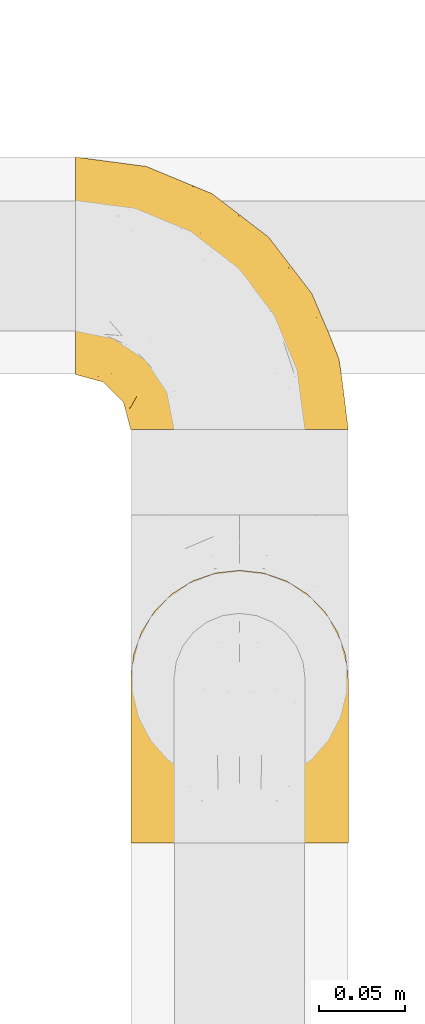
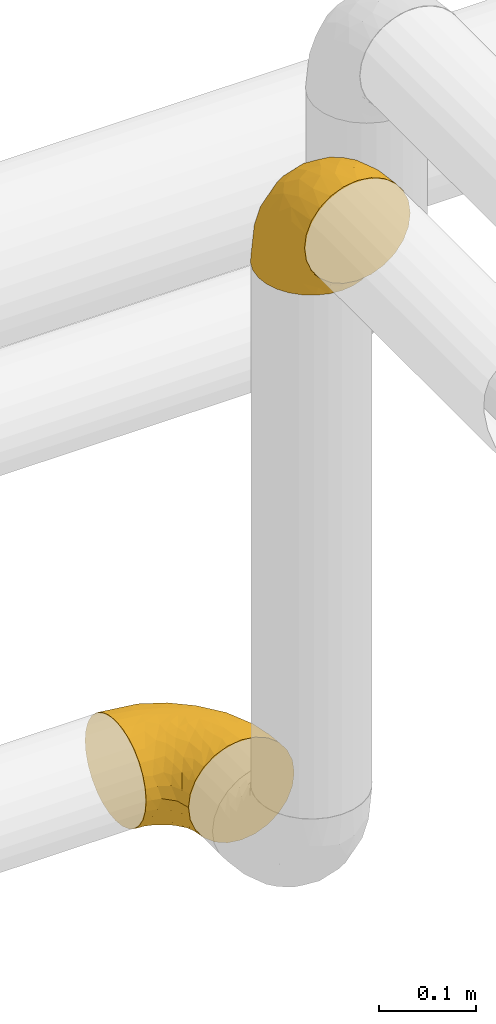
# One storey, part 120 of 827: 2 coverings.
"""IFC2X3 building model written with IfcOpenShell, lengths in millimetres."""

from ifc_helpers import new_model, entity, si_unit, converted_unit, derived_unit, direction, frame, origin, place, context, subcontext, project, spatial, faceted_brep, element, save


model = new_model("IFC2X3")

# Units and contexts
model_context = context("Model", 3, precision=0.01, world=origin(), true_north=direction((6.12303176911189e-17, 1.0)))
body_context = subcontext(model_context, "Body", "Model", "MODEL_VIEW")
ifc_project = project(units=[si_unit("LENGTHUNIT", "METRE", prefix="MILLI"), si_unit("AREAUNIT", "SQUARE_METRE"), si_unit("VOLUMEUNIT", "CUBIC_METRE"), converted_unit("PLANEANGLEUNIT", "DEGREE", entity("IfcRatioMeasure", 0.0174532925199433), si_unit("PLANEANGLEUNIT", "RADIAN"), dimensions=[0, 0, 0, 0, 0, 0, 0]), si_unit("MASSUNIT", "GRAM", prefix="KILO"), derived_unit("MASSDENSITYUNIT", [(si_unit("MASSUNIT", "GRAM", prefix="KILO"), 1), (si_unit("LENGTHUNIT", "METRE"), -3)]), derived_unit("MOMENTOFINERTIAUNIT", [(si_unit("LENGTHUNIT", "METRE"), 4)]), si_unit("TIMEUNIT", "SECOND"), si_unit("FREQUENCYUNIT", "HERTZ"), si_unit("THERMODYNAMICTEMPERATUREUNIT", "DEGREE_CELSIUS"), derived_unit("THERMALTRANSMITTANCEUNIT", [(si_unit("MASSUNIT", "GRAM", prefix="KILO"), 1), (si_unit("THERMODYNAMICTEMPERATUREUNIT", "KELVIN"), -1), (si_unit("TIMEUNIT", "SECOND"), -3)]), derived_unit("VOLUMETRICFLOWRATEUNIT", [(si_unit("LENGTHUNIT", "METRE"), 3), (si_unit("TIMEUNIT", "SECOND"), -1)]), derived_unit("MASSFLOWRATEUNIT", [(si_unit("MASSUNIT", "GRAM", prefix="KILO"), 1), (si_unit("TIMEUNIT", "SECOND"), -1)]), derived_unit("ROTATIONALFREQUENCYUNIT", [(si_unit("TIMEUNIT", "SECOND"), -1)]), si_unit("ELECTRICCURRENTUNIT", "AMPERE"), si_unit("ELECTRICVOLTAGEUNIT", "VOLT"), si_unit("POWERUNIT", "WATT"), si_unit("FORCEUNIT", "NEWTON", prefix="KILO"), si_unit("ILLUMINANCEUNIT", "LUX"), si_unit("LUMINOUSFLUXUNIT", "LUMEN"), si_unit("LUMINOUSINTENSITYUNIT", "CANDELA"), derived_unit("USERDEFINED", [(si_unit("MASSUNIT", "GRAM", prefix="KILO"), -1), (si_unit("LENGTHUNIT", "METRE"), -2), (si_unit("TIMEUNIT", "SECOND"), 3), (si_unit("LUMINOUSFLUXUNIT", "LUMEN"), 1)]), derived_unit("LINEARVELOCITYUNIT", [(si_unit("LENGTHUNIT", "METRE"), 1), (si_unit("TIMEUNIT", "SECOND"), -1)]), si_unit("PRESSUREUNIT", "PASCAL"), derived_unit("USERDEFINED", [(si_unit("LENGTHUNIT", "METRE"), -2), (si_unit("MASSUNIT", "GRAM", prefix="KILO"), 1), (si_unit("TIMEUNIT", "SECOND"), -2)]), derived_unit("LINEARFORCEUNIT", [(si_unit("MASSUNIT", "GRAM", prefix="KILO"), 1), (si_unit("LENGTHUNIT", "METRE"), 1), (si_unit("TIMEUNIT", "SECOND"), -2), (si_unit("LENGTHUNIT", "METRE"), -1)]), derived_unit("PLANARFORCEUNIT", [(si_unit("MASSUNIT", "GRAM", prefix="KILO"), 1), (si_unit("LENGTHUNIT", "METRE"), 1), (si_unit("TIMEUNIT", "SECOND"), -2), (si_unit("LENGTHUNIT", "METRE"), -2)])], contexts=[model_context])

# Site, building, storey
site_placement = place(None, origin())
site = spatial("IfcSite", under=ifc_project, at=site_placement, CompositionType="ELEMENT")
building_placement = place(site_placement, origin())
building = spatial("IfcBuilding", under=site, at=building_placement, CompositionType="ELEMENT")
storey_placement = place(building_placement, frame((0.0, 0.0, 28200.0)))
storey = spatial("IfcBuildingStorey", under=building, at=storey_placement, Name="08", CompositionType="ELEMENT", Elevation=28200.0)

# Coverings
covering_1_placement = place(storey_placement, frame((26598.99, 11733.86, 3353.4)))
element("IfcCovering", 1, at=covering_1_placement, inside=storey, Name=":ADSK_", ObjectType=":ADSK_", PredefinedType="INSULATION", context=body_context, shape_type="Brep", body=[
    faceted_brep([(3.18, 110.62, 1.6), (7.84, 123.95, 1.6), (15.35, 135.9, 1.6), (25.33, 145.89, 1.6), (37.29, 153.4, 1.6), (50.61, 158.06, 1.6), (64.65, 159.65, 1.6), (78.67, 158.06, 1.6), (92.0, 153.4, 1.6), (103.95, 145.89, 1.6), (113.94, 135.91, 1.6), (121.45, 123.95, 1.6), (126.11, 110.63, 1.6), (127.7, 96.6, 1.6), (126.11, 82.57, 1.6), (121.45, 69.24, 1.6), (113.94, 57.29, 1.6), (103.96, 47.3, 1.6), (92.0, 39.79, 1.6), (78.68, 35.13, 1.6), (64.65, 33.55, 1.6), (50.62, 35.13, 1.6), (37.29, 39.79, 1.6), (25.34, 47.3, 1.6), (15.35, 57.28, 1.6), (7.84, 69.24, 1.6), (3.18, 82.56, 1.6), (1.6, 96.6, 1.6), (64.65, 1.6, 33.55), (80.96, 1.6, 35.69), (96.17, 1.6, 41.99), (109.23, 1.6, 52.01), (119.25, 1.6, 65.07), (125.55, 1.6, 80.28), (126.29, 1.6, 85.89), (127.7, 1.6, 96.6), (125.55, 1.6, 112.91), (119.25, 1.6, 128.12), (109.23, 1.6, 141.18), (96.17, 1.6, 151.2), (80.96, 1.6, 157.5), (64.65, 1.6, 159.65), (48.33, 1.6, 157.5), (33.12, 1.6, 151.2), (20.06, 1.6, 141.18), (10.04, 1.6, 128.12), (3.74, 1.6, 112.91), (1.6, 1.6, 96.6), (3.01, 1.6, 85.89), (3.74, 1.6, 80.28), (10.04, 1.6, 65.07), (20.06, 1.6, 52.01), (33.12, 1.6, 41.99), (48.33, 1.6, 35.69), (28.19, 30.13, 145.23), (42.57, 39.4, 150.95), (30.59, 62.65, 136.48), (53.36, 28.52, 156.3), (64.65, 42.5, 154.26), (15.9, 115.57, 73.92), (18.23, 98.94, 98.94), (32.42, 111.29, 102.72), (45.22, 95.5, 124.89), (64.65, 80.62, 138.47), (64.65, 113.35, 113.35), (9.73, 43.71, 120.33), (16.54, 70.76, 118.42), (6.44, 62.71, 103.99), (4.21, 33.16, 110.05), (2.65, 53.41, 94.6), (23.51, 130.65, 62.68), (35.48, 137.68, 66.8), (33.22, 146.84, 37.71), (42.18, 66.58, 141.12), (53.52, 57.7, 148.29), (17.3, 39.88, 132.76), (64.65, 154.26, 42.5), (45.71, 152.07, 39.36), (48.33, 125.54, 96.16), (50.95, 142.81, 69.16), (6.44, 103.99, 62.71), (3.41, 79.4, 79.4), (8.33, 88.81, 88.81), (2.62, 104.86, 26.93), (6.65, 117.38, 32.13), (1.6, 57.43, 78.45), (1.6, 44.19, 85.2), (1.6, 30.95, 91.95), (22.17, 139.96, 31.66), (14.22, 127.03, 45.38), (26.48, 87.17, 118.88), (1.6, 78.45, 57.43), (1.6, 73.2, 62.69), (1.6, 67.94, 67.94), (1.6, 94.63, 13.99), (1.6, 93.29, 22.47), (1.6, 91.95, 30.95), (2.65, 94.6, 53.41), (1.6, 85.2, 44.19), (64.65, 138.47, 80.62), (1.6, 13.99, 94.63), (16.24, 40.46, 39.95), (27.48, 32.36, 33.15), (20.83, 28.71, 43.2), (3.08, 15.53, 81.77), (6.64, 29.06, 66.3), (2.74, 40.03, 75.23), (3.84, 45.36, 66.55), (3.28, 26.46, 78.18), (5.99, 47.56, 56.85), (10.3, 36.28, 54.23), (15.78, 55.57, 12.94), (24.69, 45.02, 17.42), (11.25, 57.55, 27.05), (27.69, 11.56, 44.37), (19.31, 19.2, 49.66), (37.19, 10.07, 38.88), (33.01, 21.04, 37.08), (8.24, 15.52, 66.96), (49.89, 13.84, 32.99), (50.1, 32.67, 14.52), (48.9, 24.86, 26.32), (36.15, 34.31, 22.37), (2.54, 81.47, 27.96), (3.58, 71.26, 39.47), (3.12, 81.64, 15.41), (64.65, 29.26, 17.57), (6.01, 70.65, 21.32), (64.65, 31.93, 7.61), (37.71, 27.99, 28.92), (22.19, 41.71, 28.65), (13.01, 50.14, 34.82), (12.97, 17.57, 58.27), (38.95, 37.62, 11.73), (6.55, 60.48, 40.36), (64.65, 17.57, 29.26), (2.52, 56.96, 65.12), (9.45, 48.98, 45.4), (4.58, 57.29, 53.05), (2.83, 68.25, 50.39), (92.1, 10.07, 38.88), (101.63, 16.58, 42.9), (79.39, 13.84, 32.99), (127.7, 13.99, 94.63), (79.2, 32.67, 14.52), (80.4, 24.86, 26.32), (126.41, 67.81, 50.51), (122.74, 61.09, 39.41), (125.71, 71.26, 39.47), (127.7, 57.43, 78.45), (127.7, 44.19, 85.2), (126.55, 40.03, 75.23), (118.04, 57.55, 27.05), (117.36, 51.01, 36.34), (108.2, 42.79, 28.89), (126.01, 26.46, 78.18), (122.65, 29.06, 66.3), (116.32, 17.57, 58.27), (109.98, 19.2, 49.66), (113.06, 40.46, 39.95), (107.85, 28.84, 42.42), (102.33, 33.48, 32.56), (121.05, 15.52, 66.96), (126.21, 15.53, 81.77), (118.99, 36.28, 54.23), (90.34, 37.62, 11.73), (96.28, 21.04, 37.08), (127.7, 94.63, 13.99), (127.7, 93.29, 22.47), (93.14, 34.31, 22.37), (104.6, 45.03, 17.42), (123.28, 70.65, 21.32), (126.75, 81.47, 27.96), (113.51, 55.58, 12.94), (127.7, 91.95, 30.95), (126.17, 81.64, 15.41), (91.96, 27.86, 29.3), (127.7, 78.45, 57.43), (127.7, 85.2, 44.19), (126.77, 56.96, 65.12), (125.45, 45.36, 66.55), (123.3, 47.57, 56.85), (119.94, 48.27, 46.41), (127.7, 67.94, 67.94), (124.71, 57.3, 53.04), (127.7, 30.95, 91.95), (98.7, 62.65, 136.48), (101.1, 30.13, 145.23), (111.99, 39.88, 132.76), (119.56, 43.71, 120.33), (86.72, 39.4, 150.95), (75.78, 55.79, 149.01), (75.87, 28.41, 156.33), (126.64, 53.41, 94.6), (126.67, 104.86, 26.93), (122.63, 117.39, 32.14), (122.85, 103.99, 62.71), (80.96, 125.54, 96.16), (96.87, 111.29, 102.72), (93.81, 137.69, 66.79), (126.64, 94.6, 53.41), (125.88, 79.4, 79.4), (125.08, 33.16, 110.05), (86.22, 68.78, 140.44), (105.77, 130.66, 62.68), (107.12, 139.97, 31.66), (96.19, 148.6, 29.31), (113.39, 115.58, 73.92), (115.06, 127.03, 45.39), (112.75, 70.76, 118.42), (84.07, 95.5, 124.89), (122.85, 62.71, 103.99), (120.97, 88.81, 88.81), (111.06, 98.94, 98.94), (96.3, 89.09, 122.85), (75.94, 78.72, 138.38), (80.53, 142.21, 69.18), (83.57, 152.07, 39.36)], [[[0, 1, 2, 3, 4, 5, 6, 7, 8, 9, 10, 11, 12, 13, 14, 15, 16, 17, 18, 19, 20, 21, 22, 23, 24, 25, 26, 27]], [[28, 29, 30, 31, 32, 33, 34, 35, 36, 37, 38, 39, 40, 41, 42, 43, 44, 45, 46, 47, 48, 49, 50, 51, 52, 53]], [[54, 55, 56]], [[57, 41, 58]], [[59, 60, 61]], [[62, 63, 64]], [[65, 66, 67]], [[68, 67, 69]], [[70, 71, 72]], [[55, 73, 56]], [[43, 42, 55]], [[55, 74, 73]], [[44, 75, 45]], [[44, 43, 54]], [[76, 5, 77]], [[71, 78, 79]], [[45, 75, 65]], [[46, 68, 47]], [[80, 81, 82]], [[0, 83, 84]], [[69, 85, 86, 87]], [[69, 81, 85]], [[84, 1, 0]], [[2, 88, 3]], [[4, 3, 72]], [[44, 54, 75]], [[5, 4, 77]], [[89, 2, 1]], [[72, 3, 88]], [[5, 76, 6]], [[70, 88, 89]], [[68, 65, 67]], [[88, 2, 89]], [[56, 90, 66]], [[64, 78, 62]], [[81, 91, 92, 93, 85]], [[83, 27, 94, 95, 96]], [[62, 61, 90]], [[97, 96, 98, 91]], [[80, 97, 81]], [[42, 57, 55]], [[62, 78, 61]], [[84, 89, 1]], [[78, 64, 99]], [[57, 74, 55]], [[76, 77, 79]], [[77, 72, 71]], [[82, 81, 67]], [[97, 83, 96]], [[80, 89, 84]], [[79, 78, 99]], [[71, 70, 61]], [[81, 97, 91]], [[83, 80, 84]], [[68, 87, 100, 47]], [[81, 69, 67]], [[68, 69, 87]], [[65, 46, 45]], [[65, 68, 46]], [[66, 65, 75]], [[56, 66, 75]], [[66, 60, 82]], [[71, 61, 78]], [[60, 66, 90]], [[83, 97, 80]], [[27, 83, 0]], [[59, 70, 89]], [[70, 59, 61]], [[89, 80, 59]], [[82, 59, 80]], [[55, 54, 43]], [[75, 54, 56]], [[66, 82, 67]], [[59, 82, 60]], [[41, 57, 42]], [[74, 57, 58]], [[58, 63, 74]], [[62, 74, 63]], [[74, 62, 73]], [[62, 56, 73]], [[4, 72, 77]], [[70, 72, 88]], [[76, 79, 99]], [[71, 79, 77]], [[62, 90, 56]], [[60, 90, 61]], [[101, 102, 103]], [[100, 87, 104]], [[105, 106, 107]], [[108, 104, 87]], [[107, 109, 110]], [[108, 87, 86]], [[111, 112, 113]], [[114, 51, 115]], [[116, 114, 117]], [[51, 50, 118]], [[119, 28, 53]], [[120, 121, 122]], [[98, 123, 124]], [[125, 96, 95]], [[116, 53, 52]], [[126, 121, 120]], [[104, 108, 118]], [[98, 124, 91]], [[25, 24, 127]], [[120, 128, 126]], [[122, 129, 102]], [[95, 94, 27, 26]], [[122, 102, 130]], [[125, 127, 123]], [[24, 111, 127]], [[21, 20, 128]], [[112, 130, 131]], [[48, 47, 100, 49]], [[132, 110, 115]], [[23, 111, 24]], [[129, 119, 117]], [[120, 133, 21]], [[112, 23, 22]], [[134, 113, 131]], [[121, 126, 135]], [[133, 112, 22]], [[128, 120, 21]], [[132, 51, 118]], [[120, 122, 133]], [[119, 121, 135]], [[129, 117, 102]], [[125, 26, 25]], [[26, 125, 95]], [[127, 125, 25]], [[28, 119, 135]], [[119, 53, 116]], [[127, 113, 124]], [[96, 125, 123]], [[112, 131, 113]], [[101, 103, 110]], [[85, 93, 136]], [[124, 123, 127]], [[98, 96, 123]], [[112, 111, 23]], [[127, 111, 113]], [[112, 133, 122]], [[21, 133, 22]], [[107, 110, 105]], [[110, 109, 137]], [[86, 106, 108]], [[138, 109, 136]], [[105, 118, 108]], [[107, 106, 85]], [[104, 50, 49]], [[124, 134, 139]], [[138, 93, 92]], [[92, 91, 139]], [[100, 104, 49]], [[118, 105, 132]], [[104, 118, 50]], [[110, 132, 105]], [[51, 132, 115]], [[108, 106, 105]], [[85, 106, 86]], [[114, 116, 52]], [[119, 116, 117]], [[51, 114, 52]], [[114, 115, 103]], [[117, 114, 103]], [[130, 102, 101]], [[117, 103, 102]], [[110, 103, 115]], [[130, 101, 131]], [[122, 130, 112]], [[101, 137, 131]], [[113, 134, 124]], [[137, 134, 131]], [[124, 139, 91]], [[134, 138, 139]], [[92, 139, 138]], [[110, 137, 101]], [[134, 137, 138]], [[136, 109, 107]], [[137, 109, 138]], [[85, 136, 107]], [[138, 136, 93]], [[122, 121, 129]], [[129, 121, 119]], [[30, 140, 141]], [[30, 29, 140]], [[28, 135, 142]], [[143, 35, 34, 33]], [[19, 144, 128]], [[126, 145, 135]], [[146, 147, 148]], [[149, 150, 151]], [[152, 153, 154]], [[155, 156, 151]], [[157, 31, 158]], [[159, 160, 161]], [[32, 162, 163]], [[158, 31, 30]], [[157, 164, 156]], [[126, 144, 145]], [[126, 128, 144]], [[18, 165, 19]], [[141, 166, 160]], [[14, 13, 167, 168]], [[163, 143, 33]], [[169, 165, 170]], [[18, 17, 170]], [[153, 159, 154]], [[142, 135, 145]], [[148, 171, 172]], [[159, 161, 154]], [[171, 152, 173]], [[173, 17, 16]], [[16, 15, 171]], [[158, 160, 164]], [[174, 175, 168]], [[173, 170, 17]], [[19, 128, 20]], [[174, 172, 175]], [[165, 169, 144]], [[162, 157, 156]], [[175, 172, 171]], [[144, 169, 145]], [[176, 169, 161]], [[166, 140, 142]], [[175, 171, 15]], [[168, 175, 14]], [[14, 175, 15]], [[142, 145, 176]], [[28, 142, 29]], [[148, 177, 146]], [[148, 178, 177]], [[152, 171, 148]], [[179, 180, 181]], [[164, 180, 156]], [[174, 178, 172]], [[148, 172, 178]], [[171, 173, 16]], [[170, 173, 152]], [[19, 165, 144]], [[170, 165, 18]], [[153, 182, 159]], [[146, 183, 184]], [[181, 180, 164]], [[180, 151, 156]], [[163, 155, 185]], [[155, 150, 185]], [[162, 156, 155]], [[143, 163, 185]], [[180, 179, 149]], [[32, 163, 33]], [[163, 162, 155]], [[31, 162, 32]], [[31, 157, 162]], [[164, 157, 158]], [[149, 151, 180]], [[155, 151, 150]], [[142, 140, 29]], [[141, 140, 166]], [[176, 145, 169]], [[30, 141, 158]], [[164, 160, 159]], [[158, 141, 160]], [[166, 161, 160]], [[154, 169, 170]], [[169, 154, 161]], [[152, 154, 170]], [[147, 152, 148]], [[153, 147, 182]], [[181, 182, 184]], [[164, 159, 182]], [[161, 166, 176]], [[142, 176, 166]], [[183, 146, 177]], [[184, 182, 147]], [[184, 147, 146]], [[152, 147, 153]], [[182, 181, 164]], [[179, 184, 183]], [[184, 179, 181]], [[149, 179, 183]], [[186, 187, 188]], [[37, 36, 189]], [[190, 191, 192]], [[193, 185, 150, 149]], [[194, 195, 196]], [[197, 198, 199]], [[200, 201, 177]], [[193, 202, 185]], [[203, 190, 186]], [[202, 189, 36]], [[41, 40, 192]], [[204, 205, 199]], [[9, 8, 206]], [[187, 190, 39]], [[40, 39, 190]], [[38, 37, 188]], [[207, 208, 204]], [[202, 35, 143, 185]], [[39, 38, 187]], [[195, 11, 208]], [[201, 149, 183, 177]], [[188, 189, 209]], [[197, 64, 210]], [[186, 188, 209]], [[13, 12, 194]], [[211, 201, 212]], [[12, 11, 195]], [[193, 201, 211]], [[212, 201, 196]], [[10, 208, 11]], [[213, 214, 209]], [[64, 63, 215]], [[216, 197, 199]], [[8, 217, 206]], [[7, 217, 8]], [[203, 191, 190]], [[7, 6, 76]], [[208, 205, 204]], [[205, 10, 9]], [[199, 205, 206]], [[7, 76, 217]], [[205, 208, 10]], [[216, 76, 99]], [[200, 177, 178, 174]], [[64, 197, 99]], [[63, 58, 191]], [[208, 196, 195]], [[196, 200, 194]], [[198, 197, 210]], [[216, 199, 217]], [[201, 193, 149]], [[202, 193, 211]], [[202, 211, 189]], [[35, 202, 36]], [[211, 212, 209]], [[37, 189, 188]], [[211, 209, 189]], [[213, 198, 214]], [[200, 174, 194]], [[201, 200, 196]], [[214, 198, 210]], [[213, 207, 198]], [[194, 174, 168, 167, 13]], [[195, 194, 12]], [[198, 204, 199]], [[204, 198, 207]], [[212, 207, 213]], [[196, 208, 207]], [[188, 187, 38]], [[190, 187, 186]], [[207, 212, 196]], [[209, 212, 213]], [[214, 203, 186]], [[191, 215, 63]], [[191, 203, 215]], [[192, 191, 58]], [[41, 192, 58]], [[190, 192, 40]], [[203, 210, 215]], [[64, 215, 210]], [[199, 206, 217]], [[9, 206, 205]], [[76, 216, 217]], [[99, 197, 216]], [[203, 214, 210]], [[209, 214, 186]]]),
])
covering_2_placement = place(storey_placement, frame((26567.04, 11973.41, 2535.35)))
element("IfcCovering", 2, at=covering_2_placement, inside=storey, Name=":ADSK_", ObjectType=":ADSK_", PredefinedType="INSULATION", context=body_context, shape_type="Brep", body=[
    faceted_brep([(1.6, 110.62, 126.11), (1.6, 123.95, 121.45), (1.6, 135.9, 113.94), (1.6, 145.89, 103.96), (1.6, 153.4, 92.0), (1.6, 158.06, 78.68), (1.6, 159.65, 64.65), (1.6, 158.06, 50.62), (1.6, 153.4, 37.29), (1.6, 145.89, 25.34), (1.6, 135.91, 15.35), (1.6, 123.95, 7.84), (1.6, 110.63, 3.18), (1.6, 96.6, 1.6), (1.6, 82.57, 3.18), (1.6, 69.24, 7.84), (1.6, 57.29, 15.35), (1.6, 47.3, 25.33), (1.6, 39.79, 37.29), (1.6, 35.13, 50.61), (1.6, 33.55, 64.65), (1.6, 35.13, 78.67), (1.6, 39.79, 92.0), (1.6, 47.3, 103.95), (1.6, 57.28, 113.94), (1.6, 69.24, 121.45), (1.6, 82.56, 126.11), (1.6, 96.6, 127.7), (33.55, 1.6, 64.65), (35.69, 1.6, 48.33), (41.99, 1.6, 33.12), (52.01, 1.6, 20.06), (65.07, 1.6, 10.04), (80.28, 1.6, 3.74), (85.89, 1.6, 3.01), (96.6, 1.6, 1.6), (112.91, 1.6, 3.74), (128.12, 1.6, 10.04), (141.18, 1.6, 20.06), (151.2, 1.6, 33.12), (157.5, 1.6, 48.33), (159.65, 1.6, 64.65), (157.5, 1.6, 80.96), (151.2, 1.6, 96.17), (141.18, 1.6, 109.23), (128.12, 1.6, 119.25), (112.91, 1.6, 125.55), (96.6, 1.6, 127.7), (85.89, 1.6, 126.29), (80.28, 1.6, 125.55), (65.07, 1.6, 119.25), (52.01, 1.6, 109.23), (41.99, 1.6, 96.17), (35.69, 1.6, 80.96), (145.23, 30.13, 101.1), (150.95, 39.4, 86.72), (136.48, 62.65, 98.7), (156.3, 28.52, 75.93), (154.26, 42.5, 64.65), (73.92, 115.57, 113.39), (98.94, 98.94, 111.06), (102.72, 111.29, 96.87), (124.89, 95.5, 84.07), (138.47, 80.62, 64.65), (113.35, 113.35, 64.65), (120.33, 43.71, 119.56), (118.42, 70.76, 112.75), (103.99, 62.71, 122.85), (110.05, 33.16, 125.08), (94.6, 53.41, 126.64), (62.68, 130.65, 105.78), (66.8, 137.68, 93.81), (37.71, 146.84, 96.07), (141.12, 66.58, 87.11), (148.29, 57.7, 75.77), (132.76, 39.88, 111.99), (42.5, 154.26, 64.65), (39.36, 152.07, 83.58), (96.16, 125.54, 80.96), (69.16, 142.81, 78.34), (62.71, 103.99, 122.85), (79.4, 79.4, 125.88), (88.81, 88.81, 120.97), (26.93, 104.86, 126.67), (32.13, 117.38, 122.64), (78.45, 57.43, 127.7), (85.2, 44.19, 127.7), (91.95, 30.95, 127.7), (31.66, 139.96, 107.12), (45.38, 127.03, 115.07), (118.88, 87.17, 102.81), (57.43, 78.45, 127.7), (62.69, 73.2, 127.7), (67.94, 67.94, 127.7), (13.99, 94.63, 127.7), (22.47, 93.29, 127.7), (30.95, 91.95, 127.7), (53.41, 94.6, 126.64), (44.19, 85.2, 127.7), (80.62, 138.47, 64.65), (94.63, 13.99, 127.7), (39.95, 40.46, 113.05), (33.15, 32.36, 101.81), (43.2, 28.71, 108.46), (81.77, 15.53, 126.21), (66.3, 29.06, 122.65), (75.23, 40.03, 126.55), (66.55, 45.36, 125.45), (78.18, 26.46, 126.01), (56.85, 47.56, 123.3), (54.23, 36.28, 118.99), (12.94, 55.57, 113.51), (17.42, 45.02, 104.6), (27.05, 57.55, 118.04), (44.37, 11.56, 101.6), (49.66, 19.2, 109.98), (38.88, 10.07, 92.1), (37.08, 21.04, 96.28), (66.96, 15.52, 121.05), (32.99, 13.84, 79.4), (14.52, 32.67, 79.19), (26.32, 24.86, 80.39), (22.37, 34.31, 93.14), (27.96, 81.47, 126.75), (39.47, 71.26, 125.71), (15.41, 81.64, 126.17), (17.57, 29.26, 64.65), (21.32, 70.65, 123.28), (7.61, 31.93, 64.65), (28.92, 27.99, 91.58), (28.65, 41.71, 107.1), (34.82, 50.14, 116.28), (58.27, 17.57, 116.32), (11.73, 37.62, 90.34), (40.36, 60.48, 122.74), (29.26, 17.57, 64.65), (65.12, 56.96, 126.77), (45.4, 48.98, 119.84), (53.05, 57.29, 124.71), (50.39, 68.25, 126.47), (38.88, 10.07, 37.19), (42.9, 16.58, 27.66), (32.99, 13.84, 49.9), (94.63, 13.99, 1.6), (14.52, 32.67, 50.1), (26.32, 24.86, 48.89), (50.51, 67.81, 2.88), (39.41, 61.09, 6.55), (39.47, 71.26, 3.58), (78.45, 57.43, 1.6), (85.2, 44.19, 1.6), (75.23, 40.03, 2.74), (27.05, 57.55, 11.25), (36.34, 51.01, 11.93), (28.89, 42.79, 21.09), (78.18, 26.46, 3.28), (66.3, 29.06, 6.64), (58.27, 17.57, 12.97), (49.66, 19.2, 19.31), (39.95, 40.46, 16.23), (42.42, 28.84, 21.44), (32.56, 33.48, 26.96), (66.96, 15.52, 8.24), (81.77, 15.53, 3.08), (54.23, 36.28, 10.3), (11.73, 37.62, 38.95), (37.08, 21.04, 33.01), (13.99, 94.63, 1.6), (22.47, 93.29, 1.6), (22.37, 34.31, 36.15), (17.42, 45.03, 24.69), (21.32, 70.65, 6.01), (27.96, 81.47, 2.54), (12.94, 55.58, 15.78), (30.95, 91.95, 1.6), (15.41, 81.64, 3.12), (29.3, 27.86, 37.33), (57.43, 78.45, 1.6), (44.19, 85.2, 1.6), (65.12, 56.96, 2.52), (66.55, 45.36, 3.84), (56.85, 47.57, 5.99), (46.41, 48.27, 9.35), (67.94, 67.94, 1.6), (53.04, 57.3, 4.58), (91.95, 30.95, 1.6), (136.48, 62.65, 30.59), (145.23, 30.13, 28.19), (132.76, 39.88, 17.3), (120.33, 43.71, 9.73), (150.95, 39.4, 42.57), (149.01, 55.79, 53.51), (156.33, 28.41, 53.42), (94.6, 53.41, 2.65), (26.93, 104.86, 2.62), (32.14, 117.39, 6.66), (62.71, 103.99, 6.44), (96.16, 125.54, 48.33), (102.72, 111.29, 32.42), (66.79, 137.69, 35.49), (53.41, 94.6, 2.65), (79.4, 79.4, 3.41), (110.05, 33.16, 4.21), (140.44, 68.78, 43.07), (62.68, 130.66, 23.52), (31.66, 139.97, 22.18), (29.31, 148.6, 33.1), (73.92, 115.58, 15.9), (45.39, 127.03, 14.23), (118.42, 70.76, 16.54), (124.89, 95.5, 45.22), (103.99, 62.71, 6.44), (88.81, 88.81, 8.33), (98.94, 98.94, 18.23), (122.85, 89.09, 32.99), (138.38, 78.72, 53.35), (69.18, 142.21, 48.76), (39.36, 152.07, 45.72)], [[[0, 1, 2, 3, 4, 5, 6, 7, 8, 9, 10, 11, 12, 13, 14, 15, 16, 17, 18, 19, 20, 21, 22, 23, 24, 25, 26, 27]], [[28, 29, 30, 31, 32, 33, 34, 35, 36, 37, 38, 39, 40, 41, 42, 43, 44, 45, 46, 47, 48, 49, 50, 51, 52, 53]], [[54, 55, 56]], [[57, 41, 58]], [[59, 60, 61]], [[62, 63, 64]], [[65, 66, 67]], [[68, 67, 69]], [[70, 71, 72]], [[55, 73, 56]], [[43, 42, 55]], [[55, 74, 73]], [[44, 75, 45]], [[44, 43, 54]], [[76, 5, 77]], [[71, 78, 79]], [[45, 75, 65]], [[46, 68, 47]], [[80, 81, 82]], [[0, 83, 84]], [[69, 85, 86, 87]], [[69, 81, 85]], [[84, 1, 0]], [[2, 88, 3]], [[4, 3, 72]], [[44, 54, 75]], [[5, 4, 77]], [[89, 2, 1]], [[72, 3, 88]], [[5, 76, 6]], [[70, 88, 89]], [[68, 65, 67]], [[88, 2, 89]], [[56, 90, 66]], [[64, 78, 62]], [[81, 91, 92, 93, 85]], [[83, 27, 94, 95, 96]], [[62, 61, 90]], [[97, 96, 98, 91]], [[80, 97, 81]], [[42, 57, 55]], [[62, 78, 61]], [[84, 89, 1]], [[78, 64, 99]], [[57, 74, 55]], [[76, 77, 79]], [[77, 72, 71]], [[82, 81, 67]], [[97, 83, 96]], [[80, 89, 84]], [[79, 78, 99]], [[71, 70, 61]], [[81, 97, 91]], [[83, 80, 84]], [[68, 87, 100, 47]], [[81, 69, 67]], [[68, 69, 87]], [[65, 46, 45]], [[65, 68, 46]], [[66, 65, 75]], [[56, 66, 75]], [[66, 60, 82]], [[71, 61, 78]], [[60, 66, 90]], [[83, 97, 80]], [[27, 83, 0]], [[59, 70, 89]], [[70, 59, 61]], [[89, 80, 59]], [[82, 59, 80]], [[55, 54, 43]], [[75, 54, 56]], [[66, 82, 67]], [[59, 82, 60]], [[41, 57, 42]], [[74, 57, 58]], [[58, 63, 74]], [[62, 74, 63]], [[74, 62, 73]], [[62, 56, 73]], [[4, 72, 77]], [[70, 72, 88]], [[76, 79, 99]], [[71, 79, 77]], [[62, 90, 56]], [[60, 90, 61]], [[101, 102, 103]], [[100, 87, 104]], [[105, 106, 107]], [[108, 104, 87]], [[107, 109, 110]], [[108, 87, 86]], [[111, 112, 113]], [[114, 51, 115]], [[116, 114, 117]], [[51, 50, 118]], [[119, 28, 53]], [[120, 121, 122]], [[98, 123, 124]], [[125, 96, 95]], [[116, 53, 52]], [[126, 121, 120]], [[104, 108, 118]], [[98, 124, 91]], [[25, 24, 127]], [[120, 128, 126]], [[122, 129, 102]], [[95, 94, 27, 26]], [[122, 102, 130]], [[125, 127, 123]], [[24, 111, 127]], [[21, 20, 128]], [[112, 130, 131]], [[48, 47, 100, 49]], [[132, 110, 115]], [[23, 111, 24]], [[129, 119, 117]], [[120, 133, 21]], [[112, 23, 22]], [[134, 113, 131]], [[121, 126, 135]], [[133, 112, 22]], [[128, 120, 21]], [[132, 51, 118]], [[120, 122, 133]], [[119, 121, 135]], [[129, 117, 102]], [[125, 26, 25]], [[26, 125, 95]], [[127, 125, 25]], [[28, 119, 135]], [[119, 53, 116]], [[127, 113, 124]], [[96, 125, 123]], [[112, 131, 113]], [[101, 103, 110]], [[85, 93, 136]], [[124, 123, 127]], [[98, 96, 123]], [[112, 111, 23]], [[127, 111, 113]], [[112, 133, 122]], [[21, 133, 22]], [[107, 110, 105]], [[110, 109, 137]], [[86, 106, 108]], [[138, 109, 136]], [[105, 118, 108]], [[107, 106, 85]], [[104, 50, 49]], [[124, 134, 139]], [[138, 93, 92]], [[92, 91, 139]], [[100, 104, 49]], [[118, 105, 132]], [[104, 118, 50]], [[110, 132, 105]], [[51, 132, 115]], [[108, 106, 105]], [[85, 106, 86]], [[114, 116, 52]], [[119, 116, 117]], [[51, 114, 52]], [[114, 115, 103]], [[117, 114, 103]], [[130, 102, 101]], [[117, 103, 102]], [[110, 103, 115]], [[130, 101, 131]], [[122, 130, 112]], [[101, 137, 131]], [[113, 134, 124]], [[137, 134, 131]], [[124, 139, 91]], [[134, 138, 139]], [[92, 139, 138]], [[110, 137, 101]], [[134, 137, 138]], [[136, 109, 107]], [[137, 109, 138]], [[85, 136, 107]], [[138, 136, 93]], [[122, 121, 129]], [[129, 121, 119]], [[30, 140, 141]], [[30, 29, 140]], [[28, 135, 142]], [[143, 35, 34, 33]], [[19, 144, 128]], [[126, 145, 135]], [[146, 147, 148]], [[149, 150, 151]], [[152, 153, 154]], [[155, 156, 151]], [[157, 31, 158]], [[159, 160, 161]], [[32, 162, 163]], [[158, 31, 30]], [[157, 164, 156]], [[126, 144, 145]], [[126, 128, 144]], [[18, 165, 19]], [[141, 166, 160]], [[14, 13, 167, 168]], [[163, 143, 33]], [[169, 165, 170]], [[18, 17, 170]], [[153, 159, 154]], [[142, 135, 145]], [[148, 171, 172]], [[159, 161, 154]], [[171, 152, 173]], [[173, 17, 16]], [[16, 15, 171]], [[158, 160, 164]], [[174, 175, 168]], [[173, 170, 17]], [[19, 128, 20]], [[174, 172, 175]], [[165, 169, 144]], [[162, 157, 156]], [[175, 172, 171]], [[144, 169, 145]], [[176, 169, 161]], [[166, 140, 142]], [[175, 171, 15]], [[168, 175, 14]], [[14, 175, 15]], [[142, 145, 176]], [[28, 142, 29]], [[148, 177, 146]], [[148, 178, 177]], [[152, 171, 148]], [[179, 180, 181]], [[164, 180, 156]], [[174, 178, 172]], [[148, 172, 178]], [[171, 173, 16]], [[170, 173, 152]], [[19, 165, 144]], [[170, 165, 18]], [[153, 182, 159]], [[146, 183, 184]], [[181, 180, 164]], [[180, 151, 156]], [[163, 155, 185]], [[155, 150, 185]], [[162, 156, 155]], [[143, 163, 185]], [[180, 179, 149]], [[32, 163, 33]], [[163, 162, 155]], [[31, 162, 32]], [[31, 157, 162]], [[164, 157, 158]], [[149, 151, 180]], [[155, 151, 150]], [[142, 140, 29]], [[141, 140, 166]], [[176, 145, 169]], [[30, 141, 158]], [[164, 160, 159]], [[158, 141, 160]], [[166, 161, 160]], [[154, 169, 170]], [[169, 154, 161]], [[152, 154, 170]], [[147, 152, 148]], [[153, 147, 182]], [[181, 182, 184]], [[164, 159, 182]], [[161, 166, 176]], [[142, 176, 166]], [[183, 146, 177]], [[184, 182, 147]], [[184, 147, 146]], [[152, 147, 153]], [[182, 181, 164]], [[179, 184, 183]], [[184, 179, 181]], [[149, 179, 183]], [[186, 187, 188]], [[37, 36, 189]], [[190, 191, 192]], [[193, 185, 150, 149]], [[194, 195, 196]], [[197, 198, 199]], [[200, 201, 177]], [[193, 202, 185]], [[203, 190, 186]], [[202, 189, 36]], [[41, 40, 192]], [[204, 205, 199]], [[9, 8, 206]], [[187, 190, 39]], [[40, 39, 190]], [[38, 37, 188]], [[207, 208, 204]], [[202, 35, 143, 185]], [[39, 38, 187]], [[195, 11, 208]], [[201, 149, 183, 177]], [[188, 189, 209]], [[197, 64, 210]], [[186, 188, 209]], [[13, 12, 194]], [[211, 201, 212]], [[12, 11, 195]], [[193, 201, 211]], [[212, 201, 196]], [[10, 208, 11]], [[213, 214, 209]], [[64, 63, 215]], [[216, 197, 199]], [[8, 217, 206]], [[7, 217, 8]], [[203, 191, 190]], [[7, 6, 76]], [[208, 205, 204]], [[205, 10, 9]], [[199, 205, 206]], [[7, 76, 217]], [[205, 208, 10]], [[216, 76, 99]], [[200, 177, 178, 174]], [[64, 197, 99]], [[63, 58, 191]], [[208, 196, 195]], [[196, 200, 194]], [[198, 197, 210]], [[216, 199, 217]], [[201, 193, 149]], [[202, 193, 211]], [[202, 211, 189]], [[35, 202, 36]], [[211, 212, 209]], [[37, 189, 188]], [[211, 209, 189]], [[213, 198, 214]], [[200, 174, 194]], [[201, 200, 196]], [[214, 198, 210]], [[213, 207, 198]], [[194, 174, 168, 167, 13]], [[195, 194, 12]], [[198, 204, 199]], [[204, 198, 207]], [[212, 207, 213]], [[196, 208, 207]], [[188, 187, 38]], [[190, 187, 186]], [[207, 212, 196]], [[209, 212, 213]], [[214, 203, 186]], [[191, 215, 63]], [[191, 203, 215]], [[192, 191, 58]], [[41, 192, 58]], [[190, 192, 40]], [[203, 210, 215]], [[64, 215, 210]], [[199, 206, 217]], [[9, 206, 205]], [[76, 216, 217]], [[99, 197, 216]], [[203, 214, 210]], [[209, 214, 186]]]),
])

save(model, "model.ifc")
